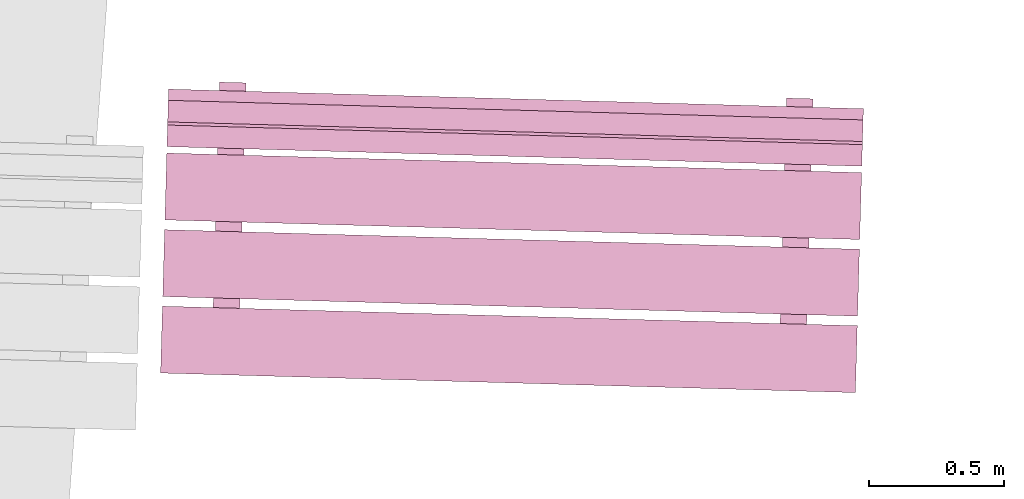
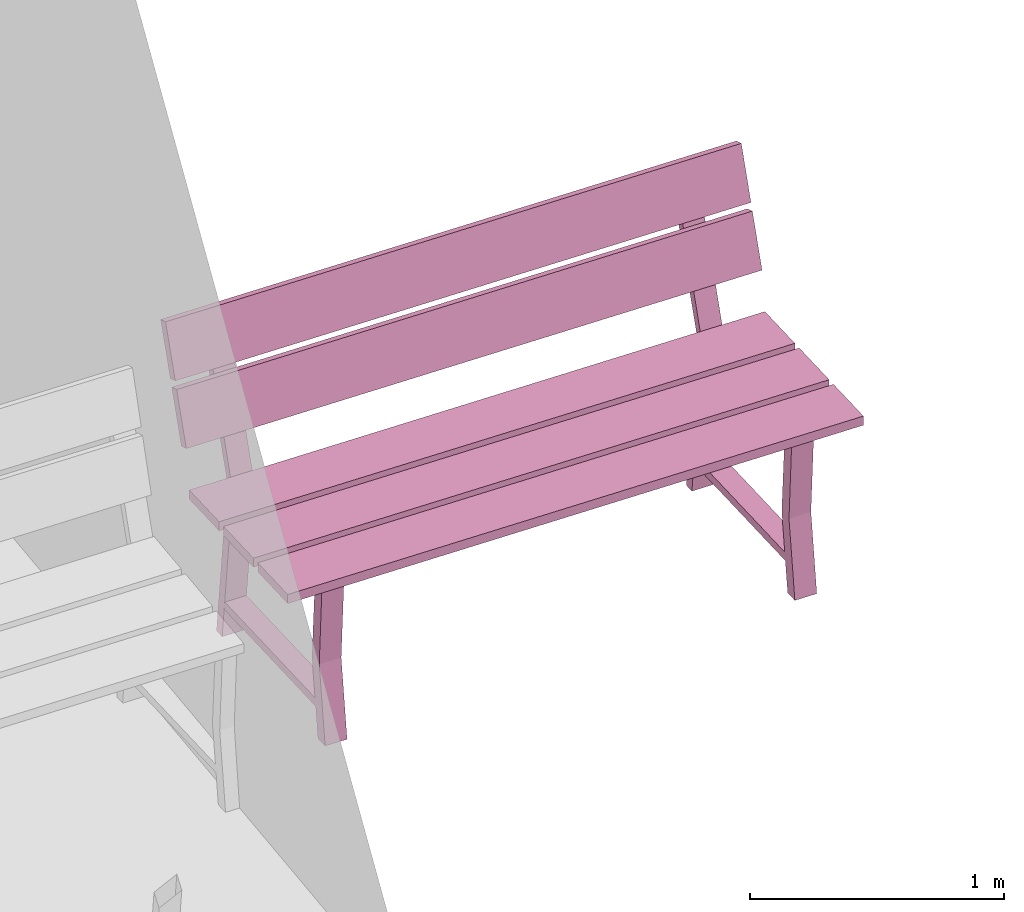
# One storey, part 21 of 200: 1 furnishing.
"""IFC4 building model written with IfcOpenShell, lengths in metres."""

from ifc_helpers import new_model, si_unit, origin_with_axes, place, context, subcontext, project, spatial, triangles, material, element, save


model = new_model("IFC4")

# Units and contexts
model_context = context("Model", 3, precision=1e-05, world=origin_with_axes())
body_context = subcontext(model_context, "Body", "Model", "MODEL_VIEW")
ifc_project = project(units=[si_unit("VOLUMEUNIT", "CUBIC_METRE"), si_unit("LENGTHUNIT", "METRE"), si_unit("AREAUNIT", "SQUARE_METRE")], contexts=[model_context])

# Site, building, storey
site_placement = place(None, origin_with_axes())
site = spatial("IfcSite", under=ifc_project, at=site_placement)
building_placement = place(site_placement, origin_with_axes())
building = spatial("IfcBuilding", under=site, at=building_placement, Name="Building")
storey_placement = place(building_placement, origin_with_axes())
storey = spatial("IfcBuildingStorey", under=building, at=storey_placement, Name="Ground")

# Furnishing
ifc_material = material(Name="bench")
furnishing_placement = place(storey_placement, origin_with_axes())
element("IfcFurnishingElement", 1, at=furnishing_placement, inside=storey, material=ifc_material, Name="cw_instances_bench_52", context=body_context, shape_type="Tessellation", body=[
    triangles([(241.86665502342268, -457.44396271788435, 0.8154595552323105), (241.87364847339654, -457.1958080413929, 0.8154595552323105), (239.29540979500868, -457.12314858772925, 0.8154595552323105), (239.28841634503485, -457.37130326422067, 0.8154595552323105), (239.47296915254674, -457.5132987557244, 0.3631407258093263), (239.5712672450523, -457.516068974695, 0.3631407258093263), (239.56989118631282, -457.56489686545035, 1.4461350578594623e-07), (239.4715930938073, -457.5621266464797, 1.4461350578594623e-07), (239.5695788588572, -457.57597945258516, 0.3631407258093263), (239.46990923321144, -457.62187653859024, 1.606816730954958e-07), (239.568207325717, -457.62464675756087, 1.606816730954958e-07), (239.47128076635167, -457.57320923361453, 0.3631407258093263), (239.59104807217486, -456.8141686574427, 0.7741643170422662), (239.59104807217486, -456.8141686574427, 0.7741643170422662), (239.59357838459403, -456.7243833780534, 0.0), (239.49528029208847, -456.72161315908284, 0.0), (239.49528029208847, -456.72161315908284, 0.0), (239.49226814202154, -456.8113848594111, 0.7741643170422662), (239.58984854801793, -456.85673241785, 0.7346366254607741), (239.49395402535163, -456.76867423684126, 1.6068167309549576e-08), (239.59225211785719, -456.7714444558119, 1.6068167309549576e-08), (239.49155045551237, -456.8539621988794, 0.7352793682213234), (239.47229017822303, -457.53739139301763, 0.7352794646303272), (239.57057921771948, -457.54048284779464, 0.7346367218697779), (239.56887725291608, -457.60087514727076, 0.7741644616557719), (239.47009732276274, -457.59809134923916, 0.7741644616557719), (241.85865669034527, -457.72777453676053, 0.8154596516413144), (241.86565013986646, -457.4796198763309, 0.8154595552323105), (239.28741146147863, -457.4069604226672, 0.8154595552323105), (239.2804180119574, -457.65511508309686, 0.8154596516413144), (241.87466693691903, -457.159669013175, 0.8154595552323105), (241.88166038644025, -456.91151435274537, 0.8154594588233067), (239.30342170805238, -456.83885489908175, 0.8154594588233067), (239.2964282585312, -457.08700955951133, 0.8154595552323105), (241.88233030956548, -456.88774288701137, 0.9999220838096051), (239.3063503587559, -456.7349350354084, 1.234838593466216), (239.3040916311776, -456.8150834333477, 0.9999220838096051), (241.88458903714374, -456.8075944890721, 1.234838593466216), (241.8849149459236, -456.79602998398053, 1.2690638219718915), (239.30893499420876, -456.64322216450114, 1.5039802352194984), (239.30667626753578, -456.72337053031686, 1.2690638219718915), (241.8871736725966, -456.7158816181648, 1.5039802352194984), (239.49923424057707, -456.57560674886935, 1.4583467364693816), (239.59753242945337, -456.57837697055584, 1.4583467364693816), (239.59104807217486, -456.8141686574427, 0.7741643170422662), (239.49226814202154, -456.8113848594111, 0.7741643170422662), (239.4916681450832, -456.84978611733465, 0.7738429536960751), (239.58997981664973, -456.8520744986575, 0.7738429536960751), (239.59645964787632, -456.61644341361205, 1.4723259616878532), (239.49814787993904, -456.61415502957334, 1.4723259616878532), (239.3052639963073, -456.77348338035955, 0.9857820483726994), (239.30751819783367, -456.6934955842616, 1.2206986544383143), (241.88350267469514, -456.84614283402317, 0.9857820483726994), (241.88575687622154, -456.7661550379253, 1.2206986544383143), (239.3078486322128, -456.6817704933905, 1.2549238829439897), (239.31010735933842, -456.60162211151294, 1.4898404890096046), (241.88608731060063, -456.7544299470541, 1.2549238829439897), (241.88834603772625, -456.6742815651766, 1.4898404890096046), (241.5765818466971, -457.5725823861959, 0.3631407258093263), (241.67487993920267, -457.57535260516653, 0.3631407258093263), (241.6735038804632, -457.62418049592185, 1.4461350578594623e-07), (241.57520578795766, -457.6214102769512, 1.4461350578594623e-07), (241.67319155300757, -457.63526308305666, 0.3631407258093263), (241.5735219273618, -457.68116016906174, 1.606816730954958e-07), (241.67182001986737, -457.68393038803237, 1.606816730954958e-07), (241.57489346050204, -457.63249286408603, 0.3631407258093263), (241.69466076632523, -456.87345228791423, 0.7741643170422662), (241.69466076632523, -456.87345228791423, 0.7741643170422662), (241.6971910787444, -456.7836670085249, 0.0), (241.59889298623884, -456.78089678955433, 0.0), (241.59889298623884, -456.78089678955433, 0.0), (241.59604138982795, -456.87067301457654, 0.7741643170422662), (241.6934612421683, -456.9160160483215, 0.7346366254607741), (241.597566719502, -456.82795786731276, 1.6068167309549576e-08), (241.69586481200756, -456.8307280862834, 1.6068167309549576e-08), (241.59516314966277, -456.9132458293509, 0.7352793682213234), (241.5759028723734, -457.5966750234891, 0.7352794646303272), (241.67419191186985, -457.59976647826613, 0.7346367218697779), (241.67248994706645, -457.66015877774225, 0.7741644616557719), (241.57387057056914, -457.6573795044046, 0.7741644616557719), (241.6030075847542, -456.6348949067507, 1.4583467364693816), (241.70114513966553, -456.63766060148004, 1.4583467364693816), (241.69466076632523, -456.87345228791423, 0.7741643170422662), (241.59604138982795, -456.87067301457654, 0.7741643170422662), (241.59528083923357, -456.9090697478062, 0.7738429536960751), (241.6935925108001, -456.911358129129, 0.7738429536960751), (241.70007235808848, -456.6757270445362, 1.4723259616878532), (241.60192122411618, -456.67344318745467, 1.4723259616878532), (241.87364847339654, -457.1958080413929, 0.8154595552323105), (239.29540979500868, -457.12314858772925, 0.7715934584772401), (239.29540979500868, -457.12314858772925, 0.8154595552323105), (241.87364847339654, -457.1958080413929, 0.7715934584772401), (241.86665502342268, -457.44396271788435, 0.771593506681742), (239.28841634503485, -457.37130326422067, 0.8154595552323105), (239.28841634503485, -457.37130326422067, 0.771593506681742), (241.86665502342268, -457.44396271788435, 0.8154595552323105), (239.4715930938073, -457.5621266464797, 1.4461350578594623e-07), (239.47128076635167, -457.57320923361453, 0.3631407258093263), (239.47296915254674, -457.5132987557244, 0.3631407258093263), (239.46990923321144, -457.62187653859024, 1.606816730954958e-07), (239.49155045551237, -456.8539621988794, 0.7352793682213234), (239.49226814202154, -456.8113848594111, 0.7741643170422662), (239.49528029208847, -456.72161315908284, 0.0), (239.49395402535163, -456.76867423684126, 1.6068167309549576e-08), (239.5695788588572, -457.57597945258516, 0.3631407258093263), (239.5712672450523, -457.516068974695, 0.3631407258093263), (239.57057921771948, -457.54048284779464, 0.7346367218697779), (239.56887725291608, -457.60087514727076, 0.7741644616557719), (239.59104807217486, -456.8141686574427, 0.7741643170422662), (239.58984854801793, -456.85673241785, 0.7346366254607741), (239.59357838459403, -456.7243833780534, 0.0), (239.59225211785719, -456.7714444558119, 1.6068167309549576e-08), (239.47229017822303, -457.53739139301763, 0.7352794646303272), (239.47009732276274, -457.59809134923916, 0.7741644616557719), (239.56989118631282, -457.56489686545035, 1.4461350578594623e-07), (239.568207325717, -457.62464675756087, 1.606816730954958e-07), (239.49923424057707, -456.57560674886935, 1.4583467364693816), (239.59645964787632, -456.61644341361205, 1.4723259616878532), (239.59753242945337, -456.57837697055584, 1.4583467364693816), (239.49814787993904, -456.61415502957334, 1.4723259616878532), (239.59081093812205, -456.78265599137984, 0.13995373726617685), (239.59081093812205, -456.78265599137984, 0.17948142884766885), (239.56900223967946, -457.55651303289085, 0.13995388187968263), (239.56898865971317, -457.5569949026622, 0.1794815734611746), (239.49444019620762, -456.7799400886532, 0.17948142884766885), (239.49476148019937, -456.7799491430202, 0.14059646395855885), (239.47296183431322, -457.5534849647866, 0.14059660857206463), (239.47261791779874, -457.5542789999355, 0.1794815734611746), (241.86565013986646, -457.4796198763309, 0.8154595552323105), (239.28741146147863, -457.4069604226672, 0.771593506681742), (239.28741146147863, -457.4069604226672, 0.8154595552323105), (241.86565013986646, -457.4796198763309, 0.771593506681742), (241.85865669034527, -457.72777453676053, 0.7715935548862439), (239.2804180119574, -457.65511508309686, 0.8154596516413144), (239.2804180119574, -457.65511508309686, 0.7715935548862439), (241.85865669034527, -457.72777453676053, 0.8154596516413144), (241.88166038644025, -456.91151435274537, 0.8154594588233067), (239.30342170805238, -456.83885489908175, 0.7715934102727381), (239.30342170805238, -456.83885489908175, 0.8154594588233067), (241.88166038644025, -456.91151435274537, 0.7715934102727381), (241.87466693646638, -457.1596690292368, 0.7715934584772401), (239.2964282585312, -457.08700955951133, 0.8154595552323105), (239.29642825807855, -457.0870095755731, 0.7715934584772401), (241.87466693691903, -457.159669013175, 0.8154595552323105), (239.30751819783367, -456.6934955842616, 1.2206986544383143), (241.88458903714374, -456.8075944890721, 1.234838593466216), (241.88575687622154, -456.7661550379253, 1.2206986544383143), (239.3063503587559, -456.7349350354084, 1.234838593466216), (241.88350267469514, -456.84614283402317, 0.9857820483726994), (239.3040916311776, -456.8150834333477, 0.9999220838096051), (239.3052639963073, -456.77348338035955, 0.9857820483726994), (241.88233030956548, -456.88774288701137, 0.9999220838096051), (239.31010735933842, -456.60162211151294, 1.4898404890096046), (241.8871736725966, -456.7158816181648, 1.5039802352194984), (241.88834603772625, -456.6742815651766, 1.4898404890096046), (239.30893499420876, -456.64322216450114, 1.5039802352194984), (241.88608731060063, -456.7544299470541, 1.2549238829439897), (239.30667626753578, -456.72337053031686, 1.2690638219718915), (239.3078486322128, -456.6817704933905, 1.2549238829439897), (241.8849149459236, -456.79602998398053, 1.2690638219718915), (241.57520578795766, -457.6214102769512, 1.4461350578594623e-07), (241.57489346050204, -457.63249286408603, 0.3631407258093263), (241.5765818466971, -457.5725823861959, 0.3631407258093263), (241.5735219273618, -457.68116016906174, 1.606816730954958e-07), (241.59516314966277, -456.9132458293509, 0.7352793682213234), (241.59604138982795, -456.87067301457654, 0.7741643170422662), (241.59889298623884, -456.78089678955433, 0.0), (241.597566719502, -456.82795786731276, 1.6068167309549576e-08), (241.67319155300757, -457.63526308305666, 0.3631407258093263), (241.67487993920267, -457.57535260516653, 0.3631407258093263), (241.67419191186985, -457.59976647826613, 0.7346367218697779), (241.67248994706645, -457.66015877774225, 0.7741644616557719), (241.69466076632523, -456.87345228791423, 0.7741643170422662), (241.6934612421683, -456.9160160483215, 0.7346366254607741), (241.6971910787444, -456.7836670085249, 0.0), (241.69586481200756, -456.8307280862834, 1.6068167309549576e-08), (241.5759028723734, -457.5966750234891, 0.7352794646303272), (241.57387057056914, -457.6573795044046, 0.7741644616557719), (241.6735038804632, -457.62418049592185, 1.4461350578594623e-07), (241.67182001986737, -457.68393038803237, 1.606816730954958e-07), (241.6030075847542, -456.6348949067507, 1.4583467364693816), (241.70007235808848, -456.6757270445362, 1.4723259616878532), (241.70114513966553, -456.63766060148004, 1.4583467364693816), (241.60192122411618, -456.67344318745467, 1.4723259616878532), (241.6945842822992, -456.84194414926117, 0.13995373726617685), (241.6945842822992, -456.84194414926117, 0.17948142884766885), (241.6727755838566, -457.6158011907722, 0.13995388187968263), (241.6727620038903, -457.61628306054354, 0.1794815734611746), (241.598052890358, -456.8392237191247, 0.17948142884766885), (241.59853472800577, -456.83923729818565, 0.14059646395855885), (241.57673508211963, -457.61277311995207, 0.14059660857206463), (241.57623061194911, -457.61356263040705, 0.1794815734611746), (241.86665502342268, -457.44396271788435, 0.8154595552323105), (241.87364847339654, -457.1958080413929, 0.7715934584772401), (241.87364847339654, -457.1958080413929, 0.8154595552323105), (241.86665502342268, -457.44396271788435, 0.771593506681742), (239.29540979500868, -457.12314858772925, 0.8154595552323105), (239.29540979500868, -457.12314858772925, 0.7715934584772401), (239.28841634503485, -457.37130326422067, 0.771593506681742), (239.28841634503485, -457.37130326422067, 0.8154595552323105), (241.85865669034527, -457.72777453676053, 0.8154596516413144), (241.86565013986646, -457.4796198763309, 0.771593506681742), (241.86565013986646, -457.4796198763309, 0.8154595552323105), (241.85865669034527, -457.72777453676053, 0.7715935548862439), (239.28741146147863, -457.4069604226672, 0.8154595552323105), (239.28741146147863, -457.4069604226672, 0.771593506681742), (239.2804180119574, -457.65511508309686, 0.7715935548862439), (239.2804180119574, -457.65511508309686, 0.8154596516413144), (241.87466693691903, -457.159669013175, 0.8154595552323105), (241.88166038644025, -456.91151435274537, 0.7715934102727381), (241.88166038644025, -456.91151435274537, 0.8154594588233067), (241.87466693646638, -457.1596690292368, 0.7715934584772401), (239.30342170805238, -456.83885489908175, 0.8154594588233067), (239.30342170805238, -456.83885489908175, 0.7715934102727381), (239.29642825807855, -457.0870095755731, 0.7715934584772401), (239.2964282585312, -457.08700955951133, 0.8154595552323105), (241.88350267469514, -456.84614283402317, 0.9857820483726994), (241.88575687622154, -456.7661550379253, 1.2206986544383143), (241.88458903714374, -456.8075944890721, 1.234838593466216), (241.88233030956548, -456.88774288701137, 0.9999220838096051), (239.3063503587559, -456.7349350354084, 1.234838593466216), (239.3052639963073, -456.77348338035955, 0.9857820483726994), (239.3040916311776, -456.8150834333477, 0.9999220838096051), (239.30751819783367, -456.6934955842616, 1.2206986544383143), (241.88608731060063, -456.7544299470541, 1.2549238829439897), (241.88834603772625, -456.6742815651766, 1.4898404890096046), (241.8871736725966, -456.7158816181648, 1.5039802352194984), (241.8849149459236, -456.79602998398053, 1.2690638219718915), (239.30893499420876, -456.64322216450114, 1.5039802352194984), (239.3078486322128, -456.6817704933905, 1.2549238829439897), (239.30667626753578, -456.72337053031686, 1.2690638219718915), (239.31010735933842, -456.60162211151294, 1.4898404890096046), (239.58997981664973, -456.8520744986575, 0.7738429536960751), (239.59645964787632, -456.61644341361205, 1.4723259616878532), (239.59753242945337, -456.57837697055584, 1.4583467364693816), (239.49226814202154, -456.8113848594111, 0.7741643170422662), (239.4916681450832, -456.84978611733465, 0.7738429536960751), (239.49814787993904, -456.61415502957334, 1.4723259616878532), (239.49923424057707, -456.57560674886935, 1.4583467364693816), (241.6935925108001, -456.911358129129, 0.7738429536960751), (241.70007235808848, -456.6757270445362, 1.4723259616878532), (241.70114513966553, -456.63766060148004, 1.4583467364693816), (241.59604138982795, -456.87067301457654, 0.7741643170422662), (241.59528083923357, -456.9090697478062, 0.7738429536960751), (241.60192122411618, -456.67344318745467, 1.4723259616878532), (241.6030075847542, -456.6348949067507, 1.4583467364693816), (239.59104807217486, -456.8141686574427, 0.7741643170422662), (239.49226814202154, -456.8113848594111, 0.7741643170422662), (239.56887725291608, -457.60087514727076, 0.7741644616557719), (239.47009732276274, -457.59809134923916, 0.7741644616557719), (239.59081093812205, -456.78265599137984, 0.17948142884766885), (239.49444019620762, -456.7799400886532, 0.17948142884766885), (239.56898865971317, -457.5569949026622, 0.1794815734611746), (239.47261791779874, -457.5542789999355, 0.1794815734611746), (241.69466076632523, -456.87345228791423, 0.7741643170422662), (241.59604138982795, -456.87067301457654, 0.7741643170422662), (241.67248994706645, -457.66015877774225, 0.7741644616557719), (241.57387057056914, -457.6573795044046, 0.7741644616557719), (241.6945842822992, -456.84194414926117, 0.17948142884766885), (241.598052890358, -456.8392237191247, 0.17948142884766885), (241.6727620038903, -457.61628306054354, 0.1794815734611746), (241.57623061194911, -457.61356263040705, 0.1794815734611746)], [[1, 2, 3], [3, 4, 1], [5, 6, 7], [7, 8, 5], [9, 10, 11], [10, 9, 12], [14, 15, 16], [17, 18, 13], [19, 20, 21], [20, 19, 22], [23, 24, 5], [24, 6, 5], [12, 9, 25], [25, 26, 12], [27, 28, 29], [29, 30, 27], [31, 32, 33], [33, 34, 31], [35, 36, 37], [35, 38, 36], [39, 40, 41], [39, 42, 40], [43, 44, 45], [45, 46, 43], [47, 48, 49], [49, 50, 47], [51, 52, 53], [54, 53, 52], [55, 56, 57], [58, 57, 56], [59, 60, 61], [61, 62, 59], [63, 64, 65], [64, 63, 66], [68, 69, 71], [70, 72, 67], [73, 74, 75], [74, 73, 76], [77, 78, 59], [78, 60, 59], [66, 63, 79], [79, 80, 66], [81, 82, 83], [83, 84, 81], [85, 86, 87], [87, 88, 85], [89, 90, 91], [89, 92, 90], [93, 94, 95], [93, 96, 94], [97, 98, 99], [97, 100, 98], [101, 102, 103], [103, 104, 101], [105, 106, 107], [107, 108, 105], [109, 110, 111], [110, 112, 111], [108, 107, 109], [107, 110, 109], [113, 99, 98], [98, 114, 113], [115, 106, 105], [105, 116, 115], [117, 118, 119], [117, 120, 118], [102, 101, 113], [113, 114, 102], [121, 122, 123], [122, 124, 123], [125, 126, 127], [127, 128, 125], [129, 130, 131], [129, 132, 130], [133, 134, 135], [133, 136, 134], [137, 138, 139], [137, 140, 138], [141, 142, 143], [141, 144, 142], [145, 146, 147], [145, 148, 146], [149, 150, 151], [149, 152, 150], [153, 154, 155], [153, 156, 154], [157, 158, 159], [157, 160, 158], [161, 162, 163], [161, 164, 162], [165, 166, 167], [167, 168, 165], [169, 170, 171], [171, 172, 169], [173, 174, 175], [174, 176, 175], [172, 171, 173], [171, 174, 173], [177, 163, 162], [162, 178, 177], [179, 170, 169], [169, 180, 179], [181, 182, 183], [181, 184, 182], [166, 165, 177], [177, 178, 166], [185, 186, 187], [186, 188, 187], [189, 190, 191], [191, 192, 189], [193, 194, 195], [194, 193, 196], [197, 198, 199], [199, 200, 197], [201, 202, 203], [202, 201, 204], [205, 206, 207], [207, 208, 205], [209, 210, 211], [210, 209, 212], [213, 214, 215], [215, 216, 213], [217, 218, 219], [219, 220, 217], [221, 222, 223], [222, 221, 224], [225, 226, 227], [227, 228, 225], [229, 230, 231], [230, 229, 232], [233, 109, 234], [109, 235, 234], [236, 237, 238], [238, 239, 236], [240, 173, 241], [173, 242, 241], [243, 244, 245], [245, 246, 243], [247, 248, 249], [248, 250, 249], [251, 252, 253], [252, 254, 253], [255, 256, 257], [256, 258, 257], [259, 260, 261], [260, 262, 261]], closed=True),
])

save(model, "model.ifc")
